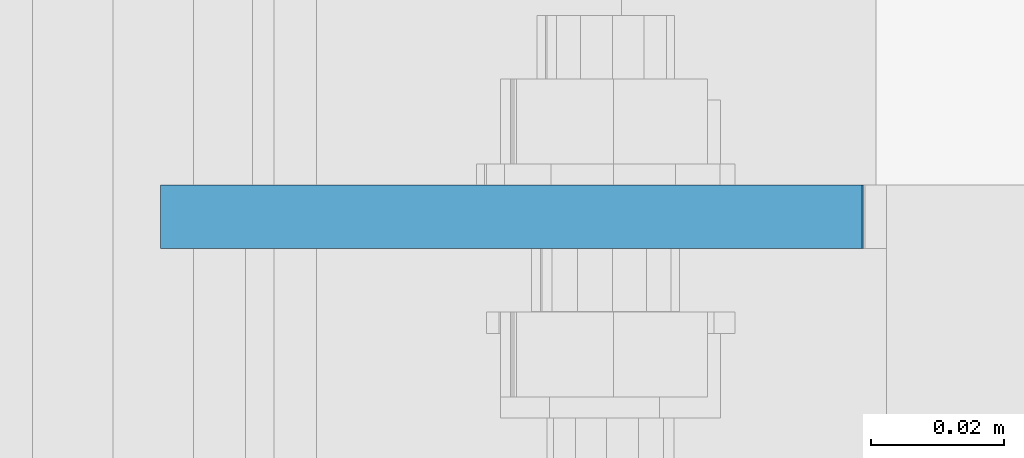
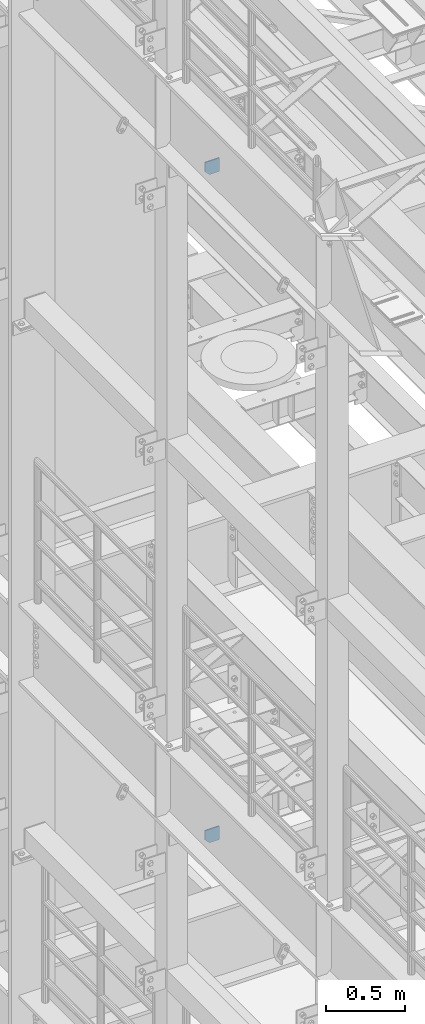
# One storey, part 1536 of 1876: 2 plates, 2 elements without a shape of their own.
"""IFC2X3 building model written with IfcOpenShell, lengths in millimetres."""

from ifc_helpers import new_model, si_unit, frame, origin_with_axes, place, context, subcontext, project, spatial, faceted_brep, material, type_object, element, aggregate, save


model = new_model("IFC2X3")

# Units and contexts
model_context = context("Model", 3, precision=1e-05, world=origin_with_axes())
body_context = subcontext(model_context, "Body", "Model", "MODEL_VIEW")
ifc_project = project(units=[si_unit("LENGTHUNIT", "METRE", prefix="MILLI"), si_unit("AREAUNIT", "SQUARE_METRE"), si_unit("VOLUMEUNIT", "CUBIC_METRE"), si_unit("MASSUNIT", "GRAM", prefix="KILO"), si_unit("TIMEUNIT", "SECOND"), si_unit("PLANEANGLEUNIT", "RADIAN"), si_unit("SOLIDANGLEUNIT", "STERADIAN"), si_unit("THERMODYNAMICTEMPERATUREUNIT", "DEGREE_CELSIUS"), si_unit("LUMINOUSINTENSITYUNIT", "LUMEN")], contexts=[model_context])

# Site, building, storey
site_placement = place(None, origin_with_axes())
site = spatial("IfcSite", under=ifc_project, at=site_placement, CompositionType="ELEMENT")
building_placement = place(site_placement, origin_with_axes())
building = spatial("IfcBuilding", under=site, at=building_placement, Name="Undefined", CompositionType="ELEMENT")
storey_placement = place(building_placement, origin_with_axes())
storey = spatial("IfcBuildingStorey", under=building, at=storey_placement, Name="Undefined", CompositionType="ELEMENT", Elevation=0.0)

# Assembly, plate
assembly_1_placement = place(storey_placement, origin_with_axes())
assembly_1 = element("IfcElementAssembly", 1, at=assembly_1_placement, inside=storey, Name="BEAM", AssemblyPlace="NOTDEFINED", PredefinedType="RIGID_FRAME")
ifc_material = material(Name="STEEL/A36")
plate_type_1 = type_object("IfcPlateType", PredefinedType="NOTDEFINED")
plate_1_placement = place(assembly_1_placement, frame((7.14374663738151, -919.162500000004, 12816.9742795602), z_axis=(0.0, 0.0, -1.0), x_axis=(1.0, 0.0, 0.0)))
plate_1 = element("IfcPlate", 2, at=plate_1_placement, type_object=plate_type_1, material=ifc_material, Name="PLATE", context=body_context, shape_type="Brep", body=[
    faceted_brep([(0.0, -4.76249999999982, 0.0), (3.36263383360347e-06, -4.76249999999999, 72.5242767333984), (3.36263383360347e-06, 4.76249999999999, 72.5242767333984), (0.0, 4.76249999999982, 0.0), (31.7500038146972, -4.76249999999999, 104.274276733398), (31.7500038146972, 4.76249999999999, 104.274276733398), (105.092643737793, -4.76249999999999, 104.274276733398), (105.092643737793, 4.76249999999999, 104.274276733398), (105.092643737793, -4.76249999999999, 0.0), (105.092643737793, 4.76249999999999, 0.0)], [[[0, 1, 2, 3]], [[1, 4, 5, 2]], [[4, 6, 7, 5]], [[6, 8, 9, 7]], [[8, 0, 3, 9]], [[5, 7, 9, 3, 2]], [[8, 6, 4, 1, 0]]]),
])
aggregate(assembly_1, [plate_1])

assembly_2_placement = place(storey_placement, origin_with_axes())
assembly_2 = element("IfcElementAssembly", 3, at=assembly_2_placement, inside=storey, Name="BEAM", AssemblyPlace="NOTDEFINED", PredefinedType="RIGID_FRAME")
plate_type_2 = type_object("IfcPlateType", PredefinedType="NOTDEFINED")
plate_2_placement = place(assembly_2_placement, frame((7.14375, -919.162500000002, 7556.5), z_axis=(0.0, 0.0, 1.0), x_axis=(1.0, 0.0, 0.0)))
plate_2 = element("IfcPlate", 4, at=plate_2_placement, type_object=plate_type_2, material=ifc_material, Name="PLATE", context=body_context, shape_type="Brep", body=[
    faceted_brep([(-9.76996261670138e-14, -4.76250000000073, 31.75), (0.0, -4.76249999999999, 103.486999511719), (0.0, 4.76249999999999, 103.486999511719), (-9.76996261670138e-14, 4.76250000000073, 31.75), (105.307250976562, -4.76249999999982, 103.486999511719), (105.307250976562, 4.76249999999982, 103.486999511719), (105.307250976562, -4.76249999999999, 0.0), (105.307250976562, 4.76249999999999, 0.0), (31.75, -4.76250000000073, 0.0), (31.75, 4.76250000000073, 0.0)], [[[0, 1, 2, 3]], [[1, 4, 5, 2]], [[4, 6, 7, 5]], [[6, 8, 9, 7]], [[8, 0, 3, 9]], [[5, 7, 9, 3, 2]], [[8, 6, 4, 1, 0]]]),
])
aggregate(assembly_2, [plate_2])

save(model, "model.ifc")
